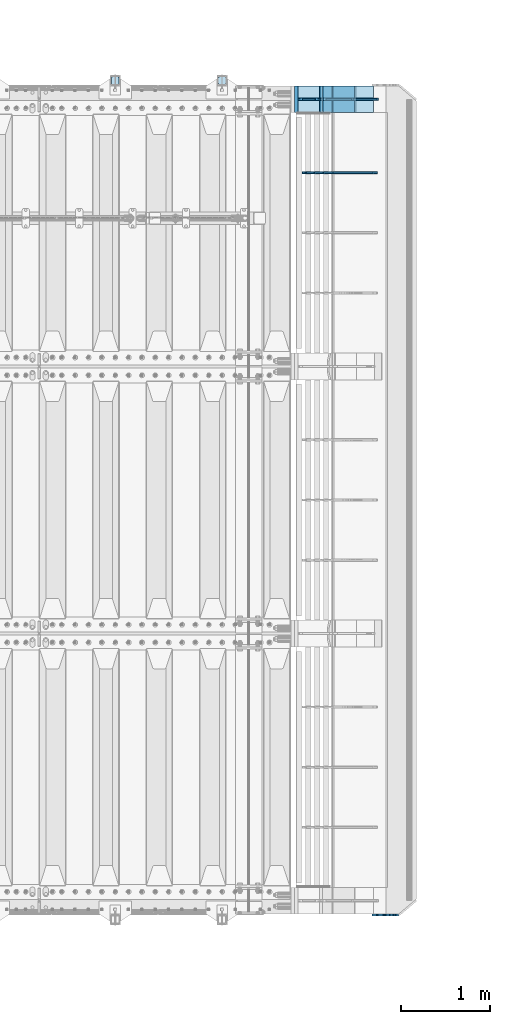
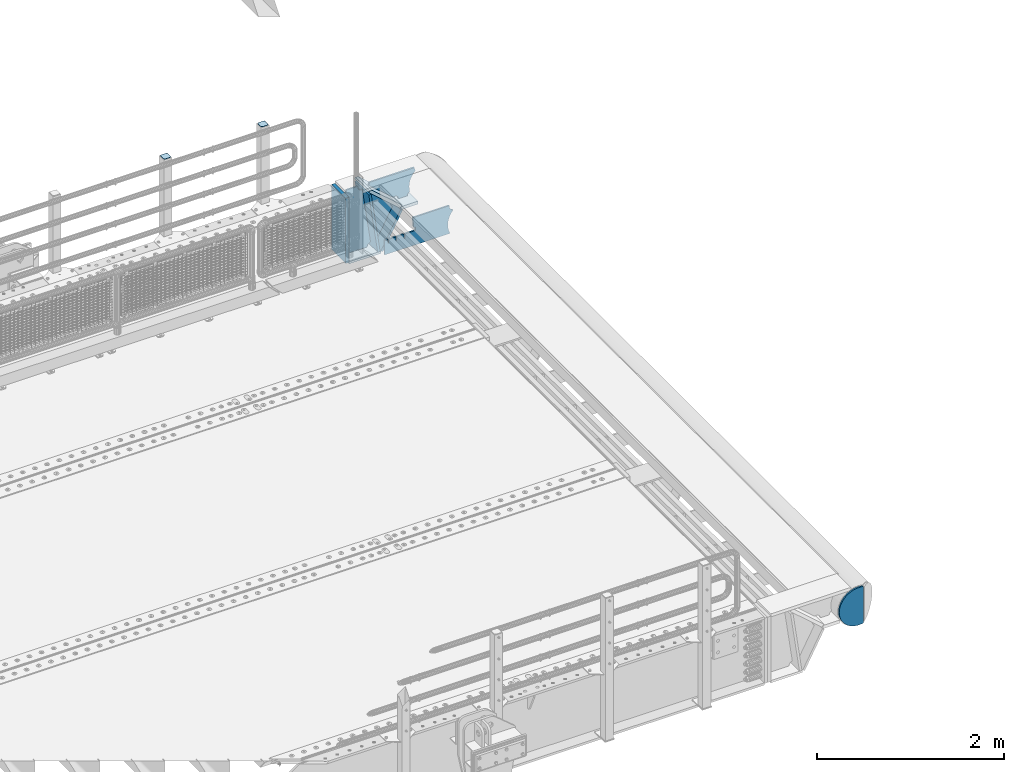
# One storey, part 204 of 219: 13 plates.
"""IFC2X3 building model written with IfcOpenShell, lengths in millimetres."""

from ifc_helpers import new_model, si_unit, frame, origin_with_axes, place, context, subcontext, project, spatial, faceted_brep, material, type_object, element, save


model = new_model("IFC2X3")

# Units and contexts
model_context = context("Model", 3, precision=1e-05, world=origin_with_axes())
body_context = subcontext(model_context, "Body", "Model", "MODEL_VIEW")
ifc_project = project(units=[si_unit("LENGTHUNIT", "METRE", prefix="MILLI"), si_unit("AREAUNIT", "SQUARE_METRE"), si_unit("VOLUMEUNIT", "CUBIC_METRE"), si_unit("MASSUNIT", "GRAM", prefix="KILO"), si_unit("TIMEUNIT", "SECOND"), si_unit("PLANEANGLEUNIT", "RADIAN"), si_unit("SOLIDANGLEUNIT", "STERADIAN"), si_unit("THERMODYNAMICTEMPERATUREUNIT", "DEGREE_CELSIUS"), si_unit("LUMINOUSINTENSITYUNIT", "LUMEN")], contexts=[model_context])

# Site, building, storey
site_placement = place(None, origin_with_axes())
site = spatial("IfcSite", under=ifc_project, at=site_placement, CompositionType="ELEMENT")
building_placement = place(site_placement, origin_with_axes())
building = spatial("IfcBuilding", under=site, at=building_placement, Name="Standard", CompositionType="ELEMENT")
storey_placement = place(building_placement, origin_with_axes())
storey = spatial("IfcBuildingStorey", under=building, at=storey_placement, Name="Undefined", CompositionType="ELEMENT", Elevation=0.0)

# Plates
ifc_material_1 = material(Name="STEEL/S355N")
plate_type_1 = type_object("IfcPlateType", PredefinedType="NOTDEFINED")
plate_1_placement = place(storey_placement, frame((14748.9988298898, 33149.9999999992, -367.999999999302), z_axis=(-0.752989422949574, 0.0, 0.658032619955932), x_axis=(0.0, -1.0, 0.0)))
element("IfcPlate", 1, at=plate_1_placement, inside=storey, type_object=plate_type_1, material=ifc_material_1, context=body_context, shape_type="Brep", body=[
    faceted_brep([(-8.11269273981452e-10, 20.0, 490.76626560162), (0.0, -0.303811250943909, 513.999999999998), (300.0, -0.303811250943909, 513.999999999998), (300.0, 20.0, 490.76626560162), (300.0, -20.0, -1.81898940354586e-12), (300.0, -20.0, 514.0), (0.0, -20.0, 514.0), (0.0, -20.0, 0.0), (0.0, 20.0, 0.0), (300.0, 20.0, -1.81898940354586e-12)], [[[0, 1, 2, 3]], [[4, 5, 6, 7]], [[4, 7, 8, 9]], [[9, 8, 0, 3]], [[5, 4, 9, 3, 2]], [[6, 5, 2, 1]], [[8, 7, 6, 1, 0]]]),
])
ifc_material_2 = material()
plate_2_placement = place(storey_placement, frame((14086.9988298906, 33150.0, -870.000000000003), z_axis=(0.0, 0.0, 1.0), x_axis=(0.0, -1.0, 0.0)))
element("IfcPlate", 2, at=plate_2_placement, inside=storey, type_object=plate_type_1, material=ifc_material_2, context=body_context, shape_type="Brep", body=[
    faceted_brep([(0.0, -20.0, 0.0), (0.0, -20.0, 850.0), (0.0, 20.0, 850.0), (0.0, 20.0, 0.0), (300.0, -20.0, 850.0), (300.0, 20.0, 850.0), (300.0, -20.0, -1.81898940354586e-12), (300.0, 20.0, -1.81898940354586e-12)], [[[0, 1, 2, 3]], [[1, 4, 5, 2]], [[4, 6, 7, 5]], [[6, 0, 3, 7]], [[5, 7, 3, 2]], [[6, 4, 1, 0]]]),
])
ifc_material_3 = material(Name="STEEL/S355J2")
plate_type_2 = type_object("IfcPlateType", PredefinedType="NOTDEFINED")
plate_3_placement = place(storey_placement, frame((13299.0000000001, 33166.0000000002, 1012.50000000001), z_axis=(0.0, 1.0, 0.0), x_axis=(-1.0, 0.0, 0.0)))
element("IfcPlate", 3, at=plate_3_placement, inside=storey, type_object=plate_type_2, material=ifc_material_3, context=body_context, shape_type="Brep", body=[
    faceted_brep([(0.0, -2.5, 19.0), (0.0, -2.5, 69.0), (0.0, 2.5, 69.0), (0.0, 2.5, 19.0), (0.476369668545885, -2.5, 73.2278977451715), (0.476369668545885, 2.5, 73.2278977451715), (1.88159150985484, -2.5, 77.2437910432345), (1.88159150985484, 2.5, 77.2437910432345), (4.14520183310742, -2.5, 80.8463062353185), (4.14520183310742, 2.5, 80.8463062353185), (7.15369376468334, -2.5, 83.8547981668889), (7.15369376468334, 2.5, 83.8547981668889), (10.7562089567673, -2.5, 86.118408490147), (10.7562089567673, 2.5, 86.118408490147), (14.7721022548303, -2.5, 87.5236303314523), (14.7721022548303, 2.5, 87.5236303314523), (19.0, -2.5, 88.0), (19.0, 2.5, 88.0), (69.0, -2.5, 88.0), (69.0, 2.5, 88.0), (73.2278977451697, -2.5, 87.5236303314523), (73.2278977451697, 2.5, 87.5236303314523), (77.2437910432327, -2.5, 86.118408490147), (77.2437910432327, 2.5, 86.118408490147), (80.8463062353167, -2.5, 83.8547981668889), (80.8463062353167, 2.5, 83.8547981668889), (83.8547981668926, -2.5, 80.8463062353185), (83.8547981668926, 2.5, 80.8463062353185), (86.1184084901452, -2.5, 77.2437910432345), (86.1184084901452, 2.5, 77.2437910432345), (87.5236303314541, -2.5, 73.2278977451715), (87.5236303314541, 2.5, 73.2278977451715), (88.0, -2.5, 69.0), (88.0, 2.5, 69.0), (88.0, -2.5, 19.0), (88.0, 2.5, 19.0), (87.5236303314541, -2.5, 14.7721022548285), (87.5236303314541, 2.5, 14.7721022548285), (86.1184084901452, -2.5, 10.7562089567655), (86.1184084901452, 2.5, 10.7562089567655), (83.8547981668926, -2.5, 7.15369376468152), (83.8547981668926, 2.5, 7.15369376468152), (80.8463062353167, -2.5, 4.14520183311106), (80.8463062353167, 2.5, 4.14520183311106), (77.2437910432345, -2.5, 1.88159150985302), (77.2437910432345, 2.5, 1.88159150985302), (73.2278977451697, -2.5, 0.476369668547704), (73.2278977451697, 2.5, 0.476369668547704), (69.0, -2.5, 0.0), (69.0, 2.5, 0.0), (19.0, -2.5, 0.0), (19.0, 2.5, 0.0), (14.7721022548303, -2.5, 0.476369668547704), (14.7721022548303, 2.5, 0.476369668547704), (10.7562089567673, -2.5, 1.88159150985302), (10.7562089567673, 2.5, 1.88159150985302), (7.15369376468334, -2.5, 4.14520183311106), (7.15369376468334, 2.5, 4.14520183311106), (4.14520183310742, -2.5, 7.15369376468152), (4.14520183310742, 2.5, 7.15369376468152), (1.88159150985484, -2.5, 10.7562089567655), (1.88159150985484, 2.5, 10.7562089567655), (0.476369668545885, -2.5, 14.7721022548285), (0.476369668545885, 2.5, 14.7721022548285)], [[[0, 1, 2, 3]], [[1, 4, 5, 2]], [[4, 6, 7, 5]], [[6, 8, 9, 7]], [[8, 10, 11, 9]], [[10, 12, 13, 11]], [[12, 14, 15, 13]], [[14, 16, 17, 15]], [[16, 18, 19, 17]], [[18, 20, 21, 19]], [[20, 22, 23, 21]], [[22, 24, 25, 23]], [[24, 26, 27, 25]], [[26, 28, 29, 27]], [[28, 30, 31, 29]], [[30, 32, 33, 31]], [[32, 34, 35, 33]], [[34, 36, 37, 35]], [[36, 38, 39, 37]], [[38, 40, 41, 39]], [[40, 42, 43, 41]], [[42, 44, 45, 43]], [[44, 46, 47, 45]], [[46, 48, 49, 47]], [[48, 50, 51, 49]], [[50, 52, 53, 51]], [[52, 54, 55, 53]], [[54, 56, 57, 55]], [[56, 58, 59, 57]], [[58, 60, 61, 59]], [[60, 62, 63, 61]], [[62, 0, 3, 63]], [[5, 7, 9, 11, 13, 15, 17, 19, 21, 23, 25, 27, 29, 31, 33, 35, 37, 39, 41, 43, 45, 47, 49, 51, 53, 55, 57, 59, 61, 63, 3, 2]], [[62, 60, 58, 56, 54, 52, 50, 48, 46, 44, 42, 40, 38, 36, 34, 32, 30, 28, 26, 24, 22, 20, 18, 16, 14, 12, 10, 8, 6, 4, 1, 0]]]),
])
plate_4_placement = place(storey_placement, frame((12099.0000000001, 33166.0000000002, 1012.50000000001), z_axis=(0.0, 1.0, 0.0), x_axis=(-1.0, 0.0, 0.0)))
element("IfcPlate", 4, at=plate_4_placement, inside=storey, type_object=plate_type_2, material=ifc_material_3, context=body_context, shape_type="Brep", body=[
    faceted_brep([(0.0, -2.5, 19.0), (0.0, -2.5, 69.0), (0.0, 2.5, 69.0), (0.0, 2.5, 19.0), (0.476369668545885, -2.5, 73.2278977451715), (0.476369668545885, 2.5, 73.2278977451715), (1.88159150985484, -2.5, 77.2437910432345), (1.88159150985484, 2.5, 77.2437910432345), (4.14520183310742, -2.5, 80.8463062353185), (4.14520183310742, 2.5, 80.8463062353185), (7.15369376468334, -2.5, 83.8547981668889), (7.15369376468334, 2.5, 83.8547981668889), (10.7562089567673, -2.5, 86.118408490147), (10.7562089567673, 2.5, 86.118408490147), (14.7721022548303, -2.5, 87.5236303314523), (14.7721022548303, 2.5, 87.5236303314523), (19.0, -2.5, 88.0), (19.0, 2.5, 88.0), (69.0, -2.5, 88.0), (69.0, 2.5, 88.0), (73.2278977451697, -2.5, 87.5236303314523), (73.2278977451697, 2.5, 87.5236303314523), (77.2437910432327, -2.5, 86.118408490147), (77.2437910432327, 2.5, 86.118408490147), (80.8463062353167, -2.5, 83.8547981668889), (80.8463062353167, 2.5, 83.8547981668889), (83.8547981668926, -2.5, 80.8463062353185), (83.8547981668926, 2.5, 80.8463062353185), (86.1184084901452, -2.5, 77.2437910432345), (86.1184084901452, 2.5, 77.2437910432345), (87.5236303314541, -2.5, 73.2278977451715), (87.5236303314541, 2.5, 73.2278977451715), (88.0, -2.5, 69.0), (88.0, 2.5, 69.0), (88.0, -2.5, 19.0), (88.0, 2.5, 19.0), (87.5236303314541, -2.5, 14.7721022548285), (87.5236303314541, 2.5, 14.7721022548285), (86.1184084901452, -2.5, 10.7562089567655), (86.1184084901452, 2.5, 10.7562089567655), (83.8547981668926, -2.5, 7.15369376468152), (83.8547981668926, 2.5, 7.15369376468152), (80.8463062353167, -2.5, 4.14520183311106), (80.8463062353167, 2.5, 4.14520183311106), (77.2437910432345, -2.5, 1.88159150985302), (77.2437910432345, 2.5, 1.88159150985302), (73.2278977451697, -2.5, 0.476369668547704), (73.2278977451697, 2.5, 0.476369668547704), (69.0, -2.5, 0.0), (69.0, 2.5, 0.0), (19.0, -2.5, 0.0), (19.0, 2.5, 0.0), (14.7721022548303, -2.5, 0.476369668547704), (14.7721022548303, 2.5, 0.476369668547704), (10.7562089567673, -2.5, 1.88159150985302), (10.7562089567673, 2.5, 1.88159150985302), (7.15369376468334, -2.5, 4.14520183311106), (7.15369376468334, 2.5, 4.14520183311106), (4.14520183310742, -2.5, 7.15369376468152), (4.14520183310742, 2.5, 7.15369376468152), (1.88159150985484, -2.5, 10.7562089567655), (1.88159150985484, 2.5, 10.7562089567655), (0.476369668545885, -2.5, 14.7721022548285), (0.476369668545885, 2.5, 14.7721022548285)], [[[0, 1, 2, 3]], [[1, 4, 5, 2]], [[4, 6, 7, 5]], [[6, 8, 9, 7]], [[8, 10, 11, 9]], [[10, 12, 13, 11]], [[12, 14, 15, 13]], [[14, 16, 17, 15]], [[16, 18, 19, 17]], [[18, 20, 21, 19]], [[20, 22, 23, 21]], [[22, 24, 25, 23]], [[24, 26, 27, 25]], [[26, 28, 29, 27]], [[28, 30, 31, 29]], [[30, 32, 33, 31]], [[32, 34, 35, 33]], [[34, 36, 37, 35]], [[36, 38, 39, 37]], [[38, 40, 41, 39]], [[40, 42, 43, 41]], [[42, 44, 45, 43]], [[44, 46, 47, 45]], [[46, 48, 49, 47]], [[48, 50, 51, 49]], [[50, 52, 53, 51]], [[52, 54, 55, 53]], [[54, 56, 57, 55]], [[56, 58, 59, 57]], [[58, 60, 61, 59]], [[60, 62, 63, 61]], [[62, 0, 3, 63]], [[5, 7, 9, 11, 13, 15, 17, 19, 21, 23, 25, 27, 29, 31, 33, 35, 37, 39, 41, 43, 45, 47, 49, 51, 53, 55, 57, 59, 61, 63, 3, 2]], [[62, 60, 58, 56, 54, 52, 50, 48, 46, 44, 42, 40, 38, 36, 34, 32, 30, 28, 26, 24, 22, 20, 18, 16, 14, 12, 10, 8, 6, 4, 1, 0]]]),
])
plate_type_3 = type_object("IfcPlateType", PredefinedType="NOTDEFINED")
plate_5_placement = place(storey_placement, frame((14748.9988298898, 32849.9999999992, -387.999999999302), z_axis=(1.0, 0.0, 0.0), x_axis=(0.0, 1.0, 0.0)))
element("IfcPlate", 5, at=plate_5_placement, inside=storey, type_object=plate_type_3, material=ifc_material_1, context=body_context, shape_type="Brep", body=[
    faceted_brep([(0.0, -20.0, 0.0), (3.31056071445346e-10, -20.0, 208.0), (3.31056071445346e-10, 20.0, 208.0), (0.0, 20.0, 0.0), (300.0, -20.0, 208.0), (300.0, 20.0, 208.0), (300.0, -20.0, -1.81898940354586e-12), (300.0, 20.0, -1.81898940354586e-12)], [[[0, 1, 2, 3]], [[1, 4, 5, 2]], [[4, 6, 7, 5]], [[6, 0, 3, 7]], [[5, 7, 3, 2]], [[6, 4, 1, 0]]]),
])
plate_type_4 = type_object("IfcPlateType", PredefinedType="NOTDEFINED")
plate_6_placement = place(storey_placement, frame((14345.998829889, 33000.0, -30.0000000032531), z_axis=(0.0, 0.0, -1.0), x_axis=(-1.0, 0.0, 0.0)))
element("IfcPlate", 6, at=plate_6_placement, inside=storey, type_object=plate_type_4, material=ifc_material_1, context=body_context, shape_type="Brep", body=[
    faceted_brep([(-9.00602409638486, -10.0, 65.0), (-108.137843376921, -10.0, 780.473130459514), (-108.137843376921, 10.0, 780.473130459514), (-9.00602409638486, 10.0, 65.0), (-94.4157884488395, -10.0, 784.433672138112), (-94.4157884488395, 10.0, 784.433672138112), (-82.3732461236723, -10.0, 792.112074067144), (-82.3732461236723, 10.0, 792.112074067144), (-72.9927947992364, -10.0, 802.881837982249), (-72.9927947992364, 10.0, 802.881837982249), (-67.0398068183713, -10.0, 815.864234368775), (-67.0398068183713, 10.0, 815.864234368775), (-65.0, -10.0, 830.0), (-65.0, 10.0, 830.0), (189.0, -10.0, 830.0), (189.0, 10.0, 830.0), (191.447174185243, -10.0, 814.549150281253), (191.447174185243, 10.0, 814.549150281253), (198.549150281253, -10.0, 800.610737385376), (198.549150281253, 10.0, 800.610737385376), (209.610737385376, -10.0, 789.549150281253), (209.610737385376, 10.0, 789.549150281253), (223.549150281253, -10.0, 782.447174185242), (223.549150281253, 10.0, 782.447174185242), (239.0, -10.0, 780.0), (239.0, 10.0, 780.0), (239.0, -10.0, 50.0), (239.0, 10.0, 50.0), (223.549150281253, -10.0, 47.5528258147577), (223.549150281253, 10.0, 47.5528258147577), (209.610737385376, -10.0, 40.4508497187474), (209.610737385376, 10.0, 40.4508497187474), (198.549150281253, -10.0, 29.3892626146237), (198.549150281253, 10.0, 29.3892626146237), (191.447174185243, -10.0, 15.4508497187474), (191.447174185243, 10.0, 15.4508497187474), (189.0, -10.0, 0.0), (189.0, 10.0, 0.0), (50.4776502774184, -10.0, 0.0), (50.4776502774184, 10.0, 0.0), (47.3830020671794, -10.0, 22.3352870825933), (47.3830020671794, 10.0, 22.3352870825933), (42.8384615202795, -10.0, 37.3040735979326), (42.8384615202795, 10.0, 37.3040735979326), (33.8907372011709, -10.0, 50.1358952937587), (33.8907372011709, 10.0, 50.1358952937587), (21.4156947086703, -10.0, 59.5746840579253), (21.4156947086703, 10.0, 59.5746840579253), (6.63447812067716, -10.0, 64.6965054822873), (6.63447812067716, 10.0, 64.6965054822873)], [[[0, 1, 2, 3]], [[1, 4, 5, 2]], [[4, 6, 7, 5]], [[6, 8, 9, 7]], [[8, 10, 11, 9]], [[10, 12, 13, 11]], [[12, 14, 15, 13]], [[14, 16, 17, 15]], [[16, 18, 19, 17]], [[18, 20, 21, 19]], [[20, 22, 23, 21]], [[22, 24, 25, 23]], [[24, 26, 27, 25]], [[26, 28, 29, 27]], [[28, 30, 31, 29]], [[30, 32, 33, 31]], [[32, 34, 35, 33]], [[34, 36, 37, 35]], [[36, 38, 39, 37]], [[38, 40, 41, 39]], [[40, 42, 43, 41]], [[42, 44, 45, 43]], [[44, 46, 47, 45]], [[46, 48, 49, 47]], [[48, 0, 3, 49]], [[5, 7, 9, 11, 13, 15, 17, 19, 21, 23, 25, 27, 29, 31, 33, 35, 37, 39, 41, 43, 45, 47, 49, 3, 2]], [[48, 46, 44, 42, 40, 38, 36, 34, 32, 30, 28, 26, 24, 22, 20, 18, 16, 14, 12, 10, 8, 6, 4, 1, 0]]]),
])
plate_type_5 = type_object("IfcPlateType", PredefinedType="NOTDEFINED")
plate_7_placement = place(storey_placement, frame((15063.9988298898, 32999.9999999994, -29.9999999993023), z_axis=(-0.000446694000103943, 0.0, -0.99999990023223), x_axis=(-0.99999990023223, 0.0, 0.000446694000103737)))
element("IfcPlate", 7, at=plate_7_placement, inside=storey, type_object=plate_type_5, material=ifc_material_1, context=body_context, shape_type="Brep", body=[
    faceted_brep([(125.007775472981, 10.0, 291.842314882029), (131.755016800049, 10.0, 263.793234614468), (131.755016800049, -10.0, 263.793234614468), (125.007775472981, -10.0, 291.842314882029), (134.899927074479, 10.0, 224.060281342732), (134.899927074479, -10.0, 224.060281342732), (131.790514995217, 10.0, 184.324534302446), (131.790514995217, -10.0, 184.324534302446), (122.503344607203, 10.0, 145.564419461128), (122.503344607203, -10.0, 145.564419461128), (107.267096867743, 10.0, 108.734339483616), (107.267096867743, -10.0, 108.734339483616), (86.4569387623869, 10.0, 74.741173170983), (86.4569387623869, -10.0, 74.741173170983), (60.5852854486457, 10.0, 44.4219450946983), (60.5852854486457, -10.0, 44.4219450946983), (56.2519855253049, 10.0, 40.7176084148888), (56.2519855253049, -10.0, 40.7176084148888), (136.409234539124, -10.0, 297.721677540594), (147.38699118058, -10.0, 308.778803581017), (147.38699118058, 10.0, 308.778803581017), (136.409234539124, 10.0, 297.721677540594), (154.428166132753, -10.0, 322.678193223937), (154.428166132753, 10.0, 322.678193223937), (156.849001662975, -10.0, 338.070097995228), (156.849001662975, 10.0, 338.070097995228), (264.849004013293, -10.0, 338.118348049693), (264.849004013293, 10.0, 338.118348049693), (267.628767119546, -10.0, 321.701412969031), (267.628767119546, 10.0, 321.701412969031), (275.645118712177, -10.0, 307.107546191754), (275.645118712177, 10.0, 307.107546191754), (288.009068357207, -10.0, 295.955165748785), (288.009068357207, 10.0, 295.955165748785), (303.34948944753, -10.0, 289.481038692482), (303.34948944753, 10.0, 289.481038692482), (319.965173216926, -10.0, 288.403127172445), (319.965173216926, 10.0, 288.403127172445), (336.013487920229, -10.0, 292.840968489265), (336.013487920229, 10.0, 292.840968489265), (335.869079589842, -10.0, 293.150054931641), (335.869079589842, 10.0, 293.150054931641), (633.937057436442, -10.0, 32.8861672876965), (633.937057436442, 10.0, 32.8861672876965), (628.672097726396, -10.0, 25.6357574923157), (628.672097726396, 10.0, 25.6357574923157), (624.785781531269, -10.0, 17.5620477266101), (624.785781531269, 10.0, 17.5620477266101), (622.402919050599, -10.0, 8.92432757904926), (622.402919050599, 10.0, 8.92432757904926), (621.600036621092, -10.0, -8.74681660434362e-10), (621.600036621092, 10.0, -8.74681660434362e-10), (69.9999999999982, -10.0, -9.85025394584227e-11), (69.9999999999982, 10.0, -9.85025394584227e-11), (67.7728137216582, -10.0, 17.5170123094482), (67.7728137216582, 10.0, 17.5170123094482), (61.2329794213983, -10.0, 33.9193489203215), (61.2329794213983, 10.0, 33.9193489203215)], [[[0, 1, 2, 3]], [[4, 5, 2, 1]], [[6, 7, 5, 4]], [[8, 9, 7, 6]], [[10, 11, 9, 8]], [[12, 13, 11, 10]], [[14, 15, 13, 12]], [[16, 17, 15, 14]], [[18, 19, 20, 21]], [[19, 22, 23, 20]], [[22, 24, 25, 23]], [[24, 26, 27, 25]], [[26, 28, 29, 27]], [[28, 30, 31, 29]], [[30, 32, 33, 31]], [[32, 34, 35, 33]], [[34, 36, 37, 35]], [[36, 38, 39, 37]], [[38, 40, 41, 39]], [[40, 42, 43, 41]], [[42, 44, 45, 43]], [[44, 46, 47, 45]], [[46, 48, 49, 47]], [[48, 50, 51, 49]], [[50, 52, 53, 51]], [[52, 54, 55, 53]], [[54, 56, 57, 55]], [[12, 10, 8, 6, 4, 1, 0, 21, 20, 23, 25, 27, 29, 31, 33, 35, 37, 39, 41, 43, 45, 47, 49, 51, 53, 55, 57, 16, 14]], [[18, 21, 0, 3]], [[56, 54, 52, 50, 48, 46, 44, 42, 40, 38, 36, 34, 32, 30, 28, 26, 24, 22, 19, 18, 3, 2, 5, 7, 9, 11, 13, 15, 17]], [[57, 56, 17, 16]]]),
])
plate_type_6 = type_object("IfcPlateType", PredefinedType="NOTDEFINED")
plate_8_placement = place(storey_placement, frame((14748.0025685034, 33000.000000001, -393.996688204407), z_axis=(-0.658066357015091, 0.0, -0.752959939017267), x_axis=(-0.752959939017267, 0.0, 0.658066357015092)))
element("IfcPlate", 8, at=plate_8_placement, inside=storey, type_object=plate_type_6, material=ifc_material_1, context=body_context, shape_type="Brep", body=[
    faceted_brep([(-11.3595226159596, -10.0, 48.6925173505897), (-112.015767301033, -10.0, 480.154833723627), (-112.015767301033, 10.0, 480.154833723627), (-11.3595226159596, 10.0, 48.6925173505897), (-104.567323293641, -10.0, 482.519601382539), (-104.567323293641, 10.0, 482.519601382539), (-97.5783311599989, -10.0, 486.016090073754), (-97.5783311599989, 10.0, 486.016090073754), (-91.2195220373815, -10.0, 490.558885551654), (-91.2195220373815, 10.0, 490.558885551654), (-85.646232588424, -10.0, 496.037013784004), (-85.646232588424, 10.0, 496.037013784004), (447.024482710496, -10.0, 32.8103372896367), (447.024482710496, 10.0, 32.8103372896367), (441.786973010394, -10.0, 25.5709623937273), (441.786973010394, 10.0, 25.5709623937273), (437.921644570128, -10.0, 17.5149526624118), (437.921644570128, 10.0, 17.5149526624118), (435.551940606496, -10.0, 8.89958500531611), (435.551940606496, 10.0, 8.89958500531611), (434.753540039064, -10.0, -5.18411980010569e-10), (434.753540039064, 10.0, -5.18411980010569e-10), (50.0, -10.0, 0.0), (50.0, 10.0, 0.0), (47.7668538974249, -10.0, 14.7759151575156), (47.7668538974249, 10.0, 14.7759151575156), (41.2668932502802, -10.0, 28.2319592212425), (41.2668932502802, 10.0, 28.2319592212425), (31.0807325300175, -10.0, 39.1661596968279), (31.0807325300175, 10.0, 39.1661596968279), (18.1182591411489, -10.0, 46.6018098971927), (18.1182591411489, 10.0, 46.6018098971927), (3.53735696080548, -10.0, 49.8747140917294), (3.53735696080548, 10.0, 49.8747140917294)], [[[0, 1, 2, 3]], [[1, 4, 5, 2]], [[4, 6, 7, 5]], [[6, 8, 9, 7]], [[8, 10, 11, 9]], [[10, 12, 13, 11]], [[12, 14, 15, 13]], [[14, 16, 17, 15]], [[16, 18, 19, 17]], [[18, 20, 21, 19]], [[20, 22, 23, 21]], [[22, 24, 25, 23]], [[24, 26, 27, 25]], [[26, 28, 29, 27]], [[28, 30, 31, 29]], [[30, 32, 33, 31]], [[32, 0, 3, 33]], [[5, 7, 9, 11, 13, 15, 17, 19, 21, 23, 25, 27, 29, 31, 33, 3, 2]], [[32, 30, 28, 26, 24, 22, 20, 18, 16, 14, 12, 10, 8, 6, 4, 1, 0]]]),
])
plate_type_7 = type_object("IfcPlateType", PredefinedType="NOTDEFINED")
plate_9_placement = place(storey_placement, frame((14499.9988298891, 33150.0, -875.000000003253), z_axis=(0.0, -1.0, 0.0), x_axis=(-1.0, 0.0, 0.0)))
element("IfcPlate", 9, at=plate_9_placement, inside=storey, type_object=plate_type_7, material=ifc_material_1, context=body_context, shape_type="Brep", body=[
    faceted_brep([(0.0, -15.0, 0.0), (0.0, -15.0, 300.0), (0.0, 15.0, 300.0), (0.0, 15.0, 0.0), (393.0, -15.0, 300.0), (393.0, 15.0, 300.0), (393.0, -15.0, 0.0), (393.0, 15.0, 0.0)], [[[0, 1, 2, 3]], [[1, 4, 5, 2]], [[4, 6, 7, 5]], [[6, 0, 3, 7]], [[5, 7, 3, 2]], [[6, 4, 1, 0]]]),
])
plate_10_placement = place(storey_placement, frame((14476.1480677219, 33150.000000001, -862.083788721732), z_axis=(-0.13917301105301, 0.0, 0.990268081377179), x_axis=(0.0, -1.0, 0.0)))
element("IfcPlate", 10, at=plate_10_placement, inside=storey, type_object=plate_type_7, material=ifc_material_1, context=body_context, shape_type="Brep", body=[
    faceted_brep([(1.00408215075731e-09, 14.9994702460517, -0.00376939769603268), (300.0, 15.0, 0.0), (300.0, -14.9999999999982, 4.21237841384573), (0.0, -14.9999999999982, 4.21237841384573), (0.0, -15.0, 792.0), (300.0, -15.0, 792.0), (300.0, 15.0, 792.0), (0.0, 15.0, 792.0)], [[[0, 1, 2, 3]], [[4, 5, 6, 7]], [[4, 7, 0, 3]], [[5, 4, 3, 2]], [[6, 5, 2, 1]], [[7, 6, 1, 0]]]),
])
plate_11_placement = place(storey_placement, frame((14513.2468009566, 33150.000000001, -867.038754739308), z_axis=(0.469471552246178, 0.0, 0.882947598462992), x_axis=(0.0, -1.0, 0.0)))
element("IfcPlate", 11, at=plate_11_placement, inside=storey, type_object=plate_type_7, material=ifc_material_1, context=body_context, shape_type="Brep", body=[
    faceted_brep([(0.0, -15.0, 0.0), (0.0, -14.9999999999982, 515.000000000001), (0.0, 15.0000000000018, 515.000000000001), (0.0, 15.0, 0.0), (300.0, -14.9999999999982, 515.000000000001), (300.0, 15.0000000000018, 515.000000000001), (300.0, -15.0, 0.0), (300.0, 15.0, 0.0)], [[[0, 1, 2, 3]], [[1, 4, 5, 2]], [[4, 6, 7, 5]], [[6, 0, 3, 7]], [[5, 7, 3, 2]], [[6, 4, 1, 0]]]),
])
plate_type_8 = type_object("IfcPlateType", PredefinedType="NOTDEFINED")
plate_12_placement = place(storey_placement, frame((14992.9182339676, 32174.9992828369, -374.002067436516), z_axis=(0.0, 0.0, 1.0), x_axis=(-1.0, 0.0, 0.0)))
element("IfcPlate", 12, at=plate_12_placement, inside=storey, type_object=plate_type_8, material=ifc_material_1, context=body_context, shape_type="Brep", body=[
    faceted_brep([(801.919404066546, -10.0, 188.0), (801.919404066546, 10.0, 188.0), (801.919404066546, 10.0, 132.002067436952), (801.919404066546, -9.99999999999636, 132.002067436952), (793.919404066546, 10.0, 132.002067436952), (793.919404066546, -9.99999999999636, 132.002067436952), (793.919404066546, 10.0, 180.002067436952), (793.919404066546, -10.0, 180.002067436952), (793.527856196908, 10.0, 182.474203391951), (793.527856196908, -10.0, 182.474203391951), (792.391540021546, 10.0, 184.704349455291), (792.391540021546, -10.0, 184.704349455291), (790.621686084885, 10.0, 186.474203391951), (790.621686084885, -10.0, 186.474203391951), (788.391540021546, 10.0, 187.610519567313), (788.391540021546, -10.0, 187.610519567313), (785.919404066546, -10.0, 188.002067436952), (785.919404066546, 10.0, 188.0), (841.0, -10.0, 188.0), (841.0, -10.0, 0.0), (841.0, 10.0, 0.0), (841.0, 10.0, 188.0), (33.3619566736033, -10.0, 0.0), (33.3619566736033, 10.0, 0.0), (36.2350612208174, -10.0, 4.68848050267013), (36.2350612208174, 10.0, 4.68848050267013), (51.487759215941, -10.0, 41.5117508652784), (51.487759215941, 10.0, 41.5117508652784), (60.792242588137, -10.0, 80.2677133162964), (60.792242588137, 10.0, 80.2677133162964), (63.9194040769726, -10.0, 120.002067436515), (63.9194040769726, 10.0, 120.002067436515), (60.792242588137, -10.0, 159.736421556734), (60.792242588137, 10.0, 159.736421556734), (51.487759215941, -10.0, 198.492384007752), (51.487759215941, 10.0, 198.492384007752), (36.2350612208174, -10.0, 235.31565437036), (36.2350612208174, 10.0, 235.31565437036), (15.4097206482093, -10.0, 269.299521518803), (15.4097206482093, 10.0, 269.299521518803), (-3.35474438098936, -10.0, 291.269887256574), (-3.35474438098936, 10.0, 291.269887256574), (-2.36881039375294, -10.0, 291.426043859339), (-2.36881039375294, 10.0, 291.426043859339), (17.1449676604734, -10.0, 301.368810393754), (17.1449676604734, 10.0, 301.368810393754), (32.6311896062471, -10.0, 316.855032339527), (32.6311896062471, 10.0, 316.855032339527), (42.5739561406608, -10.0, 336.368810393754), (42.5739561406608, 10.0, 336.368810393754), (46.0, -10.0, 358.0), (46.0, 10.0, 358.0), (45.0495205499192, -10.0, 364.001091067617), (45.0495205499192, 10.0, 364.001091067617), (495.040008544922, -10.0, 364.010009765625), (495.040008544922, 10.0, 364.010009765625), (483.600036621094, -10.0, 233.759994506836), (483.600036621094, 10.0, 233.759994506836), (472.0, -10.0, 233.759994506836), (472.0, 10.0, 233.759994506836), (468.909830056251, -10.0, 233.270559669787), (468.909830056251, 10.0, 233.270559669787), (466.122147477075, -10.0, 231.850164450585), (466.122147477075, 10.0, 231.850164450585), (463.909830056251, -10.0, 229.637847029761), (463.909830056251, 10.0, 229.637847029761), (462.489434837049, -10.0, 226.850164450585), (462.489434837049, 10.0, 226.850164450585), (462.0, -10.0, 223.759994506836), (462.0, 10.0, 223.759994506836), (462.0, -10.0, 198.0), (462.0, 10.0, 198.0), (462.489434837049, -10.0, 194.909830056251), (462.489434837049, 10.0, 194.909830056251), (463.909830056251, -10.0, 192.122147477075), (463.909830056251, 10.0, 192.122147477075), (466.122147477075, -10.0, 189.909830056251), (466.122147477075, 10.0, 189.909830056251), (468.909830056251, -10.0, 188.489434837048), (468.909830056251, 10.0, 188.489434837048), (472.0, -10.0, 188.0), (472.0, 10.0, 188.0), (585.919404066546, -10.0, 188.002067436952), (585.919404066546, 10.0, 188.0), (588.391540021546, -10.0, 187.610519567313), (588.391540021546, 10.0, 187.610519567313), (590.621686084885, -10.0, 186.474203391951), (590.621686084885, 10.0, 186.474203391951), (592.391540021546, -10.0, 184.704349455291), (592.391540021546, 10.0, 184.704349455291), (593.527856196908, -10.0, 182.474203391951), (593.527856196908, 10.0, 182.474203391951), (593.919404066546, -10.0, 180.002067436952), (593.919404066546, 10.0, 180.002067436952), (593.919404066546, -10.0, 132.002067436952), (593.919404066546, 10.0, 132.002067436952), (601.919404066546, -10.0, 132.002067436952), (601.919404066546, 10.0, 132.002067436952), (601.919404066546, -10.0, 188.0), (601.919404066546, 10.0, 188.0), (685.919404066546, -10.0, 188.002067436952), (685.919404066546, 10.0, 188.0), (688.391540021546, -10.0, 187.610519567313), (688.391540021546, 10.0, 187.610519567313), (690.621686084885, -10.0, 186.474203391951), (690.621686084885, 10.0, 186.474203391951), (692.391540021546, -10.0, 184.704349455291), (692.391540021546, 10.0, 184.704349455291), (693.527856196908, -10.0, 182.474203391951), (693.527856196908, 10.0, 182.474203391951), (693.919404066546, -10.0, 180.002067436952), (693.919404066546, 10.0, 180.002067436952), (693.919404066546, -10.0, 132.002067436952), (693.919404066546, 10.0, 132.002067436952), (701.919404066546, -10.0, 132.002067436952), (701.919404066546, 10.0, 132.002067436952), (701.919404066546, -10.0, 188.0), (701.919404066546, 10.0, 188.0)], [[[0, 1, 2, 3]], [[3, 2, 4, 5]], [[5, 4, 6, 7]], [[7, 6, 8, 9]], [[9, 8, 10, 11]], [[11, 10, 12, 13]], [[13, 12, 14, 15]], [[16, 15, 14, 17]], [[18, 19, 20, 21]], [[20, 19, 22, 23]], [[22, 24, 25, 23]], [[26, 27, 25, 24]], [[28, 29, 27, 26]], [[30, 31, 29, 28]], [[32, 33, 31, 30]], [[34, 35, 33, 32]], [[36, 37, 35, 34]], [[38, 39, 37, 36]], [[39, 38, 40, 41]], [[40, 42, 43, 41]], [[44, 45, 43, 42]], [[46, 47, 45, 44]], [[48, 49, 47, 46]], [[50, 51, 49, 48]], [[52, 53, 51, 50]], [[54, 55, 53, 52]], [[54, 56, 57, 55]], [[56, 58, 59, 57]], [[58, 60, 61, 59]], [[60, 62, 63, 61]], [[62, 64, 65, 63]], [[64, 66, 67, 65]], [[66, 68, 69, 67]], [[68, 70, 71, 69]], [[70, 72, 73, 71]], [[72, 74, 75, 73]], [[74, 76, 77, 75]], [[76, 78, 79, 77]], [[78, 80, 81, 79]], [[81, 80, 82, 83]], [[82, 84, 85, 83]], [[86, 87, 85, 84]], [[88, 89, 87, 86]], [[90, 91, 89, 88]], [[92, 93, 91, 90]], [[94, 95, 93, 92]], [[96, 97, 95, 94]], [[98, 99, 97, 96]], [[99, 98, 100, 101]], [[100, 102, 103, 101]], [[104, 105, 103, 102]], [[106, 107, 105, 104]], [[108, 109, 107, 106]], [[110, 111, 109, 108]], [[112, 113, 111, 110]], [[114, 115, 113, 112]], [[116, 117, 115, 114]], [[117, 116, 16, 17]], [[12, 10, 8, 6, 4, 2, 1, 21, 20, 23, 25, 27, 29, 31, 33, 35, 37, 39, 41, 43, 45, 47, 49, 51, 53, 55, 57, 59, 61, 63, 65, 67, 69, 71, 73, 75, 77, 79, 81, 83, 85, 87, 89, 91, 93, 95, 97, 99, 101, 103, 105, 107, 109, 111, 113, 115, 117, 17, 14]], [[18, 21, 1, 0]], [[116, 114, 112, 110, 108, 106, 104, 102, 100, 98, 96, 94, 92, 90, 88, 86, 84, 82, 80, 78, 76, 74, 72, 70, 68, 66, 64, 62, 60, 58, 56, 54, 52, 50, 48, 46, 44, 42, 40, 38, 36, 34, 32, 30, 28, 26, 24, 22, 19, 18, 0, 3, 5, 7, 9, 11, 13, 15, 16]]]),
])
plate_type_9 = type_object("IfcPlateType", PredefinedType="NOTDEFINED")
plate_13_placement = place(storey_placement, frame((15427.0025260065, 23840.0, -498.0), z_axis=(0.0, 0.0, 1.0), x_axis=(-1.0, 0.0, 0.0)))
element("IfcPlate", 13, at=plate_13_placement, inside=storey, type_object=plate_type_9, material=ifc_material_1, context=body_context, shape_type="Brep", body=[
    faceted_brep([(244.0, -10.0, 0.0), (209.275179461318, -10.0, 2.48356818105242), (209.275179461318, 10.0, 2.48356818105242), (244.0, 10.0, 0.0), (278.724820538682, -10.0, 2.48356818105236), (278.724820538682, 10.0, 2.48356818105236), (312.742743869308, -10.0, 9.88371443806261), (312.742743869308, 10.0, 9.88371443806261), (345.361263172461, -10.0, 22.0497931334975), (345.361263172461, 10.0, 22.0497931334975), (375.916359459166, -10.0, 38.7341379891918), (375.916359459166, 10.0, 38.7341379891918), (403.78601908265, -10.0, 59.597103857561), (403.78601908265, 10.0, 59.597103857561), (428.402896142439, -10.0, 84.2139809173505), (428.402896142439, 10.0, 84.2139809173505), (449.265862010809, -10.0, 112.083640540834), (449.265862010809, 10.0, 112.083640540834), (465.950206866502, -10.0, 142.63873682754), (465.950206866502, 10.0, 142.63873682754), (478.116285561937, -10.0, 175.257256130691), (478.116285561937, 10.0, 175.257256130691), (485.516431818947, -10.0, 209.275179461318), (485.516431818947, 10.0, 209.275179461318), (488.0, -10.0, 244.0), (488.0, 10.0, 244.0), (485.516431818947, -10.0, 278.724820538682), (485.516431818947, 10.0, 278.724820538682), (478.116285561937, -10.0, 312.742743869309), (478.116285561937, 10.0, 312.742743869309), (465.950206866502, -10.0, 345.36126317246), (465.950206866502, 10.0, 345.36126317246), (449.265862010809, -10.0, 375.916359459166), (449.265862010809, 10.0, 375.916359459166), (428.402896142439, -10.0, 403.78601908265), (428.402896142439, 10.0, 403.78601908265), (403.78601908265, -10.0, 428.402896142439), (403.78601908265, 10.0, 428.402896142439), (375.916359459166, -10.0, 449.265862010808), (375.916359459166, 10.0, 449.265862010808), (345.361263172461, -10.0, 465.950206866503), (345.361263172461, 10.0, 465.950206866503), (312.742743869308, -10.0, 478.116285561937), (312.742743869308, 10.0, 478.116285561937), (278.724820538682, -10.0, 485.516431818948), (278.724820538682, 10.0, 485.516431818948), (244.0, -10.0, 488.0), (244.0, 10.0, 488.0), (209.275179461318, -10.0, 485.516431818948), (209.275179461318, 10.0, 485.516431818948), (190.054561198211, -10.0, 481.33524224677), (190.057694027908, -10.0, 6.66407624784438), (190.06224403456, 10.0, 6.6630864544826), (190.059111191798, 10.0, 481.33623203729)], [[[0, 1, 2, 3]], [[4, 0, 3, 5]], [[6, 4, 5, 7]], [[8, 6, 7, 9]], [[10, 8, 9, 11]], [[12, 10, 11, 13]], [[14, 12, 13, 15]], [[16, 14, 15, 17]], [[18, 16, 17, 19]], [[20, 18, 19, 21]], [[22, 20, 21, 23]], [[24, 22, 23, 25]], [[26, 24, 25, 27]], [[28, 26, 27, 29]], [[30, 28, 29, 31]], [[32, 30, 31, 33]], [[34, 32, 33, 35]], [[36, 34, 35, 37]], [[38, 36, 37, 39]], [[40, 38, 39, 41]], [[42, 40, 41, 43]], [[44, 42, 43, 45]], [[46, 44, 45, 47]], [[48, 46, 47, 49]], [[1, 0, 4, 6, 8, 10, 12, 14, 16, 18, 20, 22, 24, 26, 28, 30, 32, 34, 36, 38, 40, 42, 44, 46, 48, 50, 51]], [[2, 1, 51, 52]], [[49, 47, 45, 43, 41, 39, 37, 35, 33, 31, 29, 27, 25, 23, 21, 19, 17, 15, 13, 11, 9, 7, 5, 3, 2, 52, 53]], [[48, 49, 53, 50]], [[52, 51, 50, 53]]]),
])

save(model, "model.ifc")
